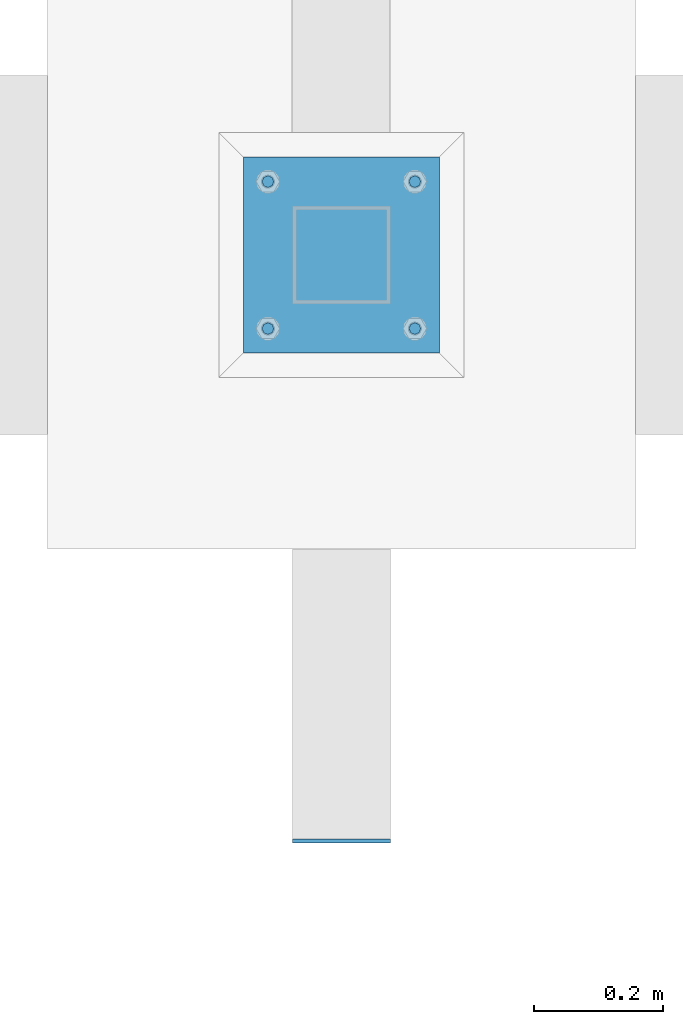
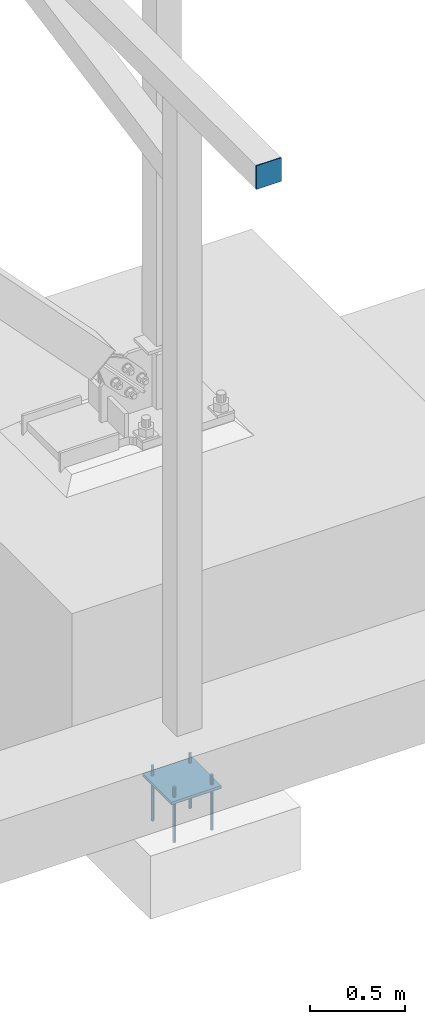
# One storey, part 847 of 1179: 7 beams, 3 elements without a shape of their own.
"""IFC2X3 building model written with IfcOpenShell, lengths in millimetres."""

from ifc_helpers import new_model, si_unit, frame, origin_with_axes, place, context, subcontext, project, spatial, faceted_brep, material, type_object, element, aggregate, save


model = new_model("IFC2X3")

# Units and contexts
model_context = context("Model", 3, precision=1e-05, world=origin_with_axes())
body_context = subcontext(model_context, "Body", "Model", "MODEL_VIEW")
ifc_project = project(units=[si_unit("LENGTHUNIT", "METRE", prefix="MILLI"), si_unit("AREAUNIT", "SQUARE_METRE"), si_unit("VOLUMEUNIT", "CUBIC_METRE"), si_unit("MASSUNIT", "GRAM", prefix="KILO"), si_unit("TIMEUNIT", "SECOND"), si_unit("PLANEANGLEUNIT", "RADIAN"), si_unit("SOLIDANGLEUNIT", "STERADIAN"), si_unit("THERMODYNAMICTEMPERATUREUNIT", "DEGREE_CELSIUS"), si_unit("LUMINOUSINTENSITYUNIT", "LUMEN")], contexts=[model_context])

# Site, building, storey
site_placement = place(None, origin_with_axes())
site = spatial("IfcSite", under=ifc_project, at=site_placement, CompositionType="ELEMENT")
building_placement = place(site_placement, origin_with_axes())
building = spatial("IfcBuilding", under=site, at=building_placement, Name="Undefined", CompositionType="ELEMENT")
storey_placement = place(building_placement, origin_with_axes())
storey = spatial("IfcBuildingStorey", under=building, at=storey_placement, Name="Undefined", CompositionType="ELEMENT", Elevation=0.0)

# Assembly, beam
assembly_1_placement = place(storey_placement, origin_with_axes())
assembly_1 = element("IfcElementAssembly", 1, at=assembly_1_placement, inside=storey, Name="BEAM", AssemblyPlace="NOTDEFINED", PredefinedType="RIGID_FRAME")
ifc_material_1 = material(Name="STEEL/A36")
beam_type_1 = type_object("IfcBeamType", PredefinedType="NOTDEFINED")
beam_1_placement = place(assembly_1_placement, frame((33731.2, 1323.97500000001, 3702.05), z_axis=(0.0, 0.0, 1.0), x_axis=(-1.0, 0.0, 0.0)))
beam_1 = element("IfcBeam", 2, at=beam_1_placement, type_object=beam_type_1, material=ifc_material_1, Name="PLATE", context=body_context, shape_type="Brep", body=[
    faceted_brep([(-1.47792889038101e-12, 3.17500000000018, -76.1999999999953), (1.36424205265939e-12, 3.17500000000018, 76.1999999999953), (152.399999999989, 3.17500000000018, 76.200000000028), (152.399999999986, 3.17500000000018, -76.1999999999625), (1.36424205265939e-12, -3.17500000000018, 76.1999999999953), (152.399999999989, -3.17500000000018, 76.200000000028), (-1.47792889038101e-12, -3.17500000000018, -76.1999999999953), (152.399999999986, -3.17500000000018, -76.1999999999625)], [[[0, 1, 2, 3]], [[1, 4, 5, 2]], [[4, 6, 7, 5]], [[6, 0, 3, 7]], [[5, 7, 3, 2]], [[6, 4, 1, 0]]]),
])
aggregate(assembly_1, [beam_1])

assembly_2_placement = place(storey_placement, origin_with_axes())
assembly_2 = element("IfcElementAssembly", 3, at=assembly_2_placement, inside=storey, Name="COLUMN", AssemblyPlace="NOTDEFINED", PredefinedType="RIGID_FRAME")
ifc_material_2 = material(Name="STEEL/A572-GR.50")
beam_type_2 = type_object("IfcBeamType", PredefinedType="NOTDEFINED")
beam_2_placement = place(assembly_2_placement, frame((33655.0, 2082.80000305176, -765.175), z_axis=(-1.0, 0.0, 0.0), x_axis=(0.0, 1.0, 0.0)))
beam_2 = element("IfcBeam", 4, at=beam_2_placement, type_object=beam_type_2, material=ifc_material_2, context=body_context, shape_type="Brep", body=[
    faceted_brep([(0.0, 9.52500000000146, -152.4), (0.0, 9.52500000000146, 152.4), (304.799993896484, 9.52499999999998, 152.400000000001), (304.799993896484, 9.52499999999998, -152.400000000001), (0.0, -9.52500000000146, 152.4), (304.799993896484, -9.52499999999998, 152.400000000001), (0.0, -9.52500000000146, -152.4), (304.799993896484, -9.52499999999998, -152.400000000001)], [[[0, 1, 2, 3]], [[1, 4, 5, 2]], [[4, 6, 7, 5]], [[6, 0, 3, 7]], [[5, 7, 3, 2]], [[6, 4, 1, 0]]]),
])
aggregate(assembly_2, [beam_2])

# Assembly, beams
assembly_3_placement = place(storey_placement, origin_with_axes())
assembly_3 = element("IfcElementAssembly", 5, at=assembly_3_placement, inside=storey, Name="TEMPLATE", AssemblyPlace="NOTDEFINED", PredefinedType="RIGID_FRAME")
ifc_material_3 = material(Name="STEEL/F1554-GR.36")
beam_type_3 = type_object("IfcBeamType", PredefinedType="NOTDEFINED")
beam_3_placement = place(assembly_3_placement, frame((33540.7, 2120.9, -812.8), z_axis=(0.0, -1.0, 0.0), x_axis=(0.0, 0.0, -1.0)))
beam_3 = element("IfcBeam", 6, at=beam_3_placement, type_object=beam_type_3, material=ifc_material_3, Name="ANCHOR_BOLT", context=body_context, shape_type="Brep", body=[
    faceted_brep([(0.0, -6.73519209080177, -6.73519209080223), (2.95075507493764e-12, -3.62376795237651e-13, -9.52499961853027), (234.949, 0.0, -9.52500000000009), (234.949, -6.73519209080405, -6.73519209080177), (0.0, 6.73519209080177, -6.73519209080223), (234.949, 6.73519209080405, -6.73519209080177), (0.0, 9.52499999999964, 0.0), (234.949, 9.52500000000146, 0.0), (0.0, 6.73519209080177, 6.73519209080223), (234.949, 6.73519209080405, 6.73519209080177), (-9.87109982941227e-13, -3.62376795237651e-13, 9.52499961853027), (234.949, 0.0, 9.52500000000009), (0.0, -6.73519209080177, 6.73519209080223), (234.949, -6.73519209080405, 6.73519209080177), (0.0, -9.52499999999964, 0.0), (234.949, -9.52500000000146, 0.0), (0.0, 6.36396103067818, 6.36396103067909), (0.0, 0.0, 9.0), (0.0, -6.36396103067818, 6.36396103067909), (0.0, -9.0, 0.0), (0.0, -6.36396103067818, -6.36396103067909), (0.0, 0.0, -9.0), (0.0, 6.36396103067818, -6.36396103067909), (0.0, 9.0, 0.0), (-120.65, -6.36396103067818, 6.36396103067909), (-120.65, 0.0, 9.0), (-120.65, 6.36396103067818, 6.36396103067909), (-120.65, 9.0, 0.0), (-120.65, 6.36396103067818, -6.36396103067909), (-120.65, 0.0, -9.0), (-120.65, -6.36396103067818, -6.36396103067909), (-120.65, -9.0, 0.0)], [[[0, 1, 2, 3]], [[1, 4, 5, 2]], [[4, 6, 7, 5]], [[6, 8, 9, 7]], [[8, 10, 11, 9]], [[10, 12, 13, 11]], [[12, 14, 15, 13]], [[2, 5, 7, 9, 11, 13, 15, 3]], [[14, 0, 3, 15]], [[12, 10, 8, 6, 4, 1, 0, 14], [16, 17, 18, 19, 20, 21, 22, 23]], [[24, 25, 26, 27, 28, 29, 30, 31]], [[26, 25, 17, 16]], [[27, 26, 16, 23]], [[28, 27, 23, 22]], [[29, 28, 22, 21]], [[30, 29, 21, 20]], [[31, 30, 20, 19]], [[24, 31, 19, 18]], [[25, 24, 18, 17]]]),
])
beam_4_placement = place(assembly_3_placement, frame((33769.3, 2120.9, -812.8), z_axis=(0.0, 1.0, 0.0), x_axis=(0.0, 0.0, -1.0)))
beam_4 = element("IfcBeam", 7, at=beam_4_placement, type_object=beam_type_3, material=ifc_material_3, Name="ANCHOR_BOLT", context=body_context, shape_type="Brep", body=[
    faceted_brep([(0.0, -6.73519209080177, -6.73519209080223), (2.95075507493764e-12, -3.62376795237651e-13, -9.52499961853027), (234.949, 0.0, -9.52500000000009), (234.949, -6.73519209080405, -6.73519209080177), (0.0, 6.73519209080177, -6.73519209080223), (234.949, 6.73519209080405, -6.73519209080177), (0.0, 9.52499999999964, 0.0), (234.949, 9.52500000000146, 0.0), (0.0, 6.73519209080177, 6.73519209080223), (234.949, 6.73519209080405, 6.73519209080177), (-9.87109982941227e-13, -3.62376795237651e-13, 9.52499961853027), (234.949, 0.0, 9.52500000000009), (0.0, -6.73519209080177, 6.73519209080223), (234.949, -6.73519209080405, 6.73519209080177), (0.0, -9.52499999999964, 0.0), (234.949, -9.52500000000146, 0.0), (0.0, 6.36396103067818, 6.36396103067909), (0.0, 0.0, 9.0), (0.0, -6.36396103067818, 6.36396103067909), (0.0, -9.0, 0.0), (0.0, -6.36396103067818, -6.36396103067909), (0.0, 0.0, -9.0), (0.0, 6.36396103067818, -6.36396103067909), (0.0, 9.0, 0.0), (-120.65, -6.36396103067818, 6.36396103067909), (-120.65, 0.0, 9.0), (-120.65, 6.36396103067818, 6.36396103067909), (-120.65, 9.0, 0.0), (-120.65, 6.36396103067818, -6.36396103067909), (-120.65, 0.0, -9.0), (-120.65, -6.36396103067818, -6.36396103067909), (-120.65, -9.0, 0.0)], [[[0, 1, 2, 3]], [[1, 4, 5, 2]], [[4, 6, 7, 5]], [[6, 8, 9, 7]], [[8, 10, 11, 9]], [[10, 12, 13, 11]], [[12, 14, 15, 13]], [[2, 5, 7, 9, 11, 13, 15, 3]], [[14, 0, 3, 15]], [[12, 10, 8, 6, 4, 1, 0, 14], [16, 17, 18, 19, 20, 21, 22, 23]], [[24, 25, 26, 27, 28, 29, 30, 31]], [[26, 25, 17, 16]], [[27, 26, 16, 23]], [[28, 27, 23, 22]], [[29, 28, 22, 21]], [[30, 29, 21, 20]], [[31, 30, 20, 19]], [[24, 31, 19, 18]], [[25, 24, 18, 17]]]),
])
beam_5_placement = place(assembly_3_placement, frame((33540.7, 2349.5, -812.8), z_axis=(0.0, -1.0, 0.0), x_axis=(0.0, 0.0, -1.0)))
beam_5 = element("IfcBeam", 8, at=beam_5_placement, type_object=beam_type_3, material=ifc_material_3, Name="ANCHOR_BOLT", context=body_context, shape_type="Brep", body=[
    faceted_brep([(0.0, -6.73519209080177, -6.73519209080223), (2.95075507493764e-12, -3.62376795237651e-13, -9.52499961853027), (234.949, 0.0, -9.52500000000009), (234.949, -6.73519209080405, -6.73519209080177), (0.0, 6.73519209080177, -6.73519209080223), (234.949, 6.73519209080405, -6.73519209080177), (0.0, 9.52499999999964, 0.0), (234.949, 9.52500000000146, 0.0), (0.0, 6.73519209080177, 6.73519209080223), (234.949, 6.73519209080405, 6.73519209080177), (-9.87109982941227e-13, -3.62376795237651e-13, 9.52499961853027), (234.949, 0.0, 9.52500000000009), (0.0, -6.73519209080177, 6.73519209080223), (234.949, -6.73519209080405, 6.73519209080177), (0.0, -9.52499999999964, 0.0), (234.949, -9.52500000000146, 0.0), (0.0, 6.36396103067818, 6.36396103067909), (0.0, 0.0, 9.0), (0.0, -6.36396103067818, 6.36396103067909), (0.0, -9.0, 0.0), (0.0, -6.36396103067818, -6.36396103067909), (0.0, 0.0, -9.0), (0.0, 6.36396103067818, -6.36396103067909), (0.0, 9.0, 0.0), (-120.65, -6.36396103067818, 6.36396103067909), (-120.65, 0.0, 9.0), (-120.65, 6.36396103067818, 6.36396103067909), (-120.65, 9.0, 0.0), (-120.65, 6.36396103067818, -6.36396103067909), (-120.65, 0.0, -9.0), (-120.65, -6.36396103067818, -6.36396103067909), (-120.65, -9.0, 0.0)], [[[0, 1, 2, 3]], [[1, 4, 5, 2]], [[4, 6, 7, 5]], [[6, 8, 9, 7]], [[8, 10, 11, 9]], [[10, 12, 13, 11]], [[12, 14, 15, 13]], [[2, 5, 7, 9, 11, 13, 15, 3]], [[14, 0, 3, 15]], [[12, 10, 8, 6, 4, 1, 0, 14], [16, 17, 18, 19, 20, 21, 22, 23]], [[24, 25, 26, 27, 28, 29, 30, 31]], [[26, 25, 17, 16]], [[27, 26, 16, 23]], [[28, 27, 23, 22]], [[29, 28, 22, 21]], [[30, 29, 21, 20]], [[31, 30, 20, 19]], [[24, 31, 19, 18]], [[25, 24, 18, 17]]]),
])
beam_6_placement = place(assembly_3_placement, frame((33769.3, 2349.5, -812.8), z_axis=(0.0, 1.0, 0.0), x_axis=(0.0, 0.0, -1.0)))
beam_6 = element("IfcBeam", 9, at=beam_6_placement, type_object=beam_type_3, material=ifc_material_3, Name="ANCHOR_BOLT", context=body_context, shape_type="Brep", body=[
    faceted_brep([(0.0, -6.73519209080177, -6.73519209080223), (2.95075507493764e-12, -3.62376795237651e-13, -9.52499961853027), (234.949, 0.0, -9.52500000000009), (234.949, -6.73519209080405, -6.73519209080177), (0.0, 6.73519209080177, -6.73519209080223), (234.949, 6.73519209080405, -6.73519209080177), (0.0, 9.52499999999964, 0.0), (234.949, 9.52500000000146, 0.0), (0.0, 6.73519209080177, 6.73519209080223), (234.949, 6.73519209080405, 6.73519209080177), (-9.87109982941227e-13, -3.62376795237651e-13, 9.52499961853027), (234.949, 0.0, 9.52500000000009), (0.0, -6.73519209080177, 6.73519209080223), (234.949, -6.73519209080405, 6.73519209080177), (0.0, -9.52499999999964, 0.0), (234.949, -9.52500000000146, 0.0), (0.0, 6.36396103067818, 6.36396103067909), (0.0, 0.0, 9.0), (0.0, -6.36396103067818, 6.36396103067909), (0.0, -9.0, 0.0), (0.0, -6.36396103067818, -6.36396103067909), (0.0, 0.0, -9.0), (0.0, 6.36396103067818, -6.36396103067909), (0.0, 9.0, 0.0), (-120.65, -6.36396103067818, 6.36396103067909), (-120.65, 0.0, 9.0), (-120.65, 6.36396103067818, 6.36396103067909), (-120.65, 9.0, 0.0), (-120.65, 6.36396103067818, -6.36396103067909), (-120.65, 0.0, -9.0), (-120.65, -6.36396103067818, -6.36396103067909), (-120.65, -9.0, 0.0)], [[[0, 1, 2, 3]], [[1, 4, 5, 2]], [[4, 6, 7, 5]], [[6, 8, 9, 7]], [[8, 10, 11, 9]], [[10, 12, 13, 11]], [[12, 14, 15, 13]], [[2, 5, 7, 9, 11, 13, 15, 3]], [[14, 0, 3, 15]], [[12, 10, 8, 6, 4, 1, 0, 14], [16, 17, 18, 19, 20, 21, 22, 23]], [[24, 25, 26, 27, 28, 29, 30, 31]], [[26, 25, 17, 16]], [[27, 26, 16, 23]], [[28, 27, 23, 22]], [[29, 28, 22, 21]], [[30, 29, 21, 20]], [[31, 30, 20, 19]], [[24, 31, 19, 18]], [[25, 24, 18, 17]]]),
])
beam_type_4 = type_object("IfcBeamType", PredefinedType="NOTDEFINED")
beam_7_placement = place(assembly_3_placement, frame((33655.0, 2082.80000305176, -773.1125), z_axis=(-1.0, 0.0, 0.0), x_axis=(0.0, 1.0, 0.0)))
beam_7 = element("IfcBeam", 10, at=beam_7_placement, type_object=beam_type_4, material=ifc_material_1, Name="TEMPLATE", context=body_context, shape_type="Brep", body=[
    faceted_brep([(0.0, 1.58750000000146, -152.4), (0.0, 1.58750000000146, 152.4), (304.799999999996, 1.58749999999998, 152.400000000001), (304.799999999996, 1.58749999999998, -152.400000000001), (0.0, -1.58750000000146, 152.4), (304.799999999996, -1.58749999999998, 152.400000000001), (0.0, -1.58750000000146, -152.4), (304.799999999996, -1.58749999999998, -152.400000000001)], [[[0, 1, 2, 3]], [[1, 4, 5, 2]], [[4, 6, 7, 5]], [[6, 0, 3, 7]], [[5, 7, 3, 2]], [[6, 4, 1, 0]]]),
])
aggregate(assembly_3, [beam_3, beam_4, beam_5, beam_6, beam_7])

save(model, "model.ifc")
